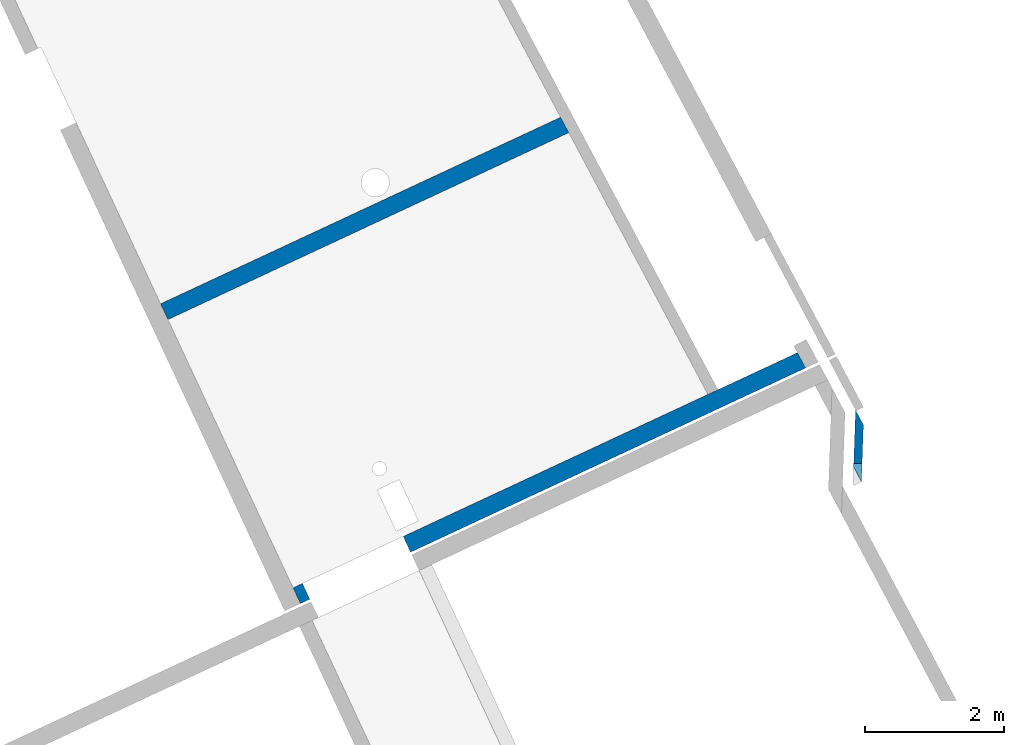
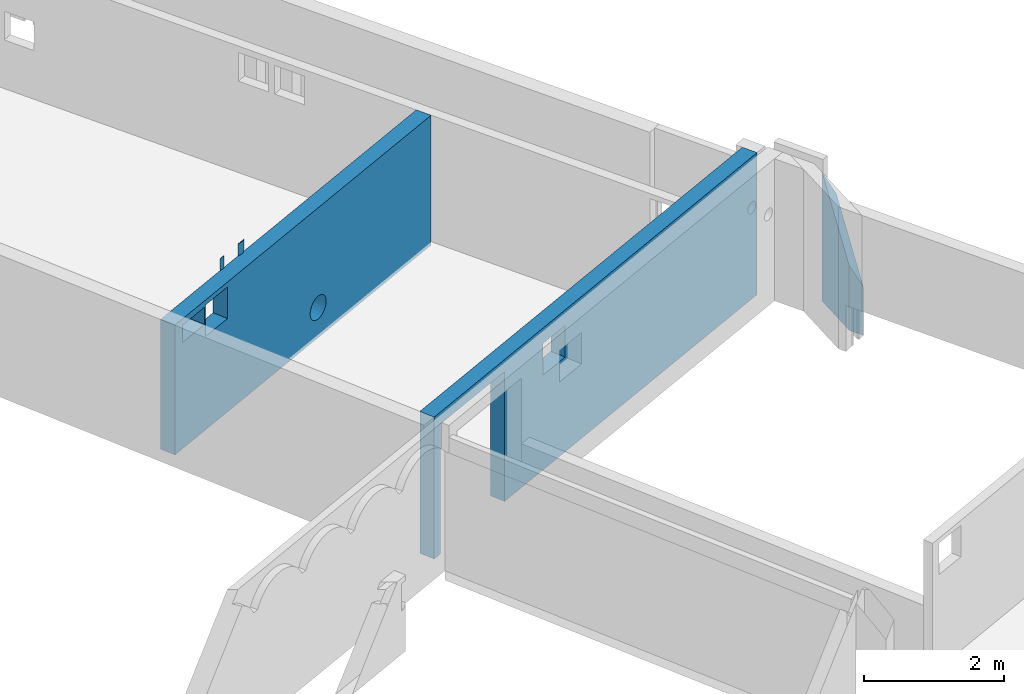
# One storey, part 10 of 13: 3 walls.
"""IFC2X3 building model written with IfcOpenShell, lengths in metres."""

import ifcopenshell
import ifcopenshell.guid

model = None  # the IFC model being written
_history = None  # IfcOwnerHistory: only IFC2X3 demands one
_inside = {}  # id of a spatial element -> (the spatial element, [elements in it])
_under = {}  # id of a project, library or spatial element -> (it, [spatial elements below it])
_declared = {}  # id of a project -> (the project, [libraries it declares])
_typed = {}  # id of a type object -> (the type object, [elements of that type])
_made_of = {}  # id of a material, layer set ... -> (it, [elements and type objects made of it])


def new_model(schema):
    """Start an empty IFC model of exactly this schema.

    Asked for "IFC4X3", IfcOpenShell would pick the latest addendum, in which some entities
    have other attributes; the version numbers below select the first issue.
    IFC2X3 requires an IfcOwnerHistory on every rooted entity: one is made here for all.
    """
    global model, _history
    if schema == "IFC4X3":
        model = ifcopenshell.file(schema_version=(4, 3, 0, 0))
    else:
        model = ifcopenshell.file(schema=schema)
    _inside.clear()
    _under.clear()
    _declared.clear()
    _typed.clear()
    _made_of.clear()
    _history = None
    if model.schema == "IFC2X3":
        org = make("IfcOrganization", Name="unknown")
        user = make(
            "IfcPersonAndOrganization",
            ThePerson=make("IfcPerson", FamilyName="unknown"),
            TheOrganization=org,
        )
        app = make(
            "IfcApplication",
            ApplicationDeveloper=org,
            Version="unknown",
            ApplicationFullName="unknown",
            ApplicationIdentifier="unknown",
        )
        _history = make(
            "IfcOwnerHistory",
            OwningUser=user,
            OwningApplication=app,
            ChangeAction="ADDED",
            CreationDate=0,
        )
    return model


def make(cls, **values):
    """One entity of the class cls with the attributes given. An attribute that is None is left unset."""
    return model.create_entity(
        cls, **{name: value for name, value in values.items() if value is not None}
    )


def entity(cls, *values):
    """Any entity or typed value of the class cls, its attributes in the order of the schema. None: left unset."""
    e = model.create_entity(cls)
    for i, value in enumerate(values):
        if value is not None:
            e[i] = value
    return e


def rooted(cls, **values):
    """An entity with a GlobalId (a new one), such as an element, a storey or a relation."""
    return make(cls, GlobalId=ifcopenshell.guid.new(), OwnerHistory=_history, **values)


def si_unit(unit_type, name, prefix=None):
    """IfcSIUnit, for example si_unit("LENGTHUNIT", "METRE", prefix="MILLI")."""
    return make("IfcSIUnit", UnitType=unit_type, Prefix=prefix, Name=name)


def converted_unit(unit_type, name, factor, base, dimensions=None, offset=None):
    """IfcConversionBasedUnit, such as the inch: factor (a typed value) times the base unit."""
    return make(
        "IfcConversionBasedUnit"
        if offset is None
        else "IfcConversionBasedUnitWithOffset",
        ConversionOffset=offset,
        Dimensions=None
        if dimensions is None
        else entity("IfcDimensionalExponents", *dimensions),
        UnitType=unit_type,
        Name=name,
        ConversionFactor=make(
            "IfcMeasureWithUnit", ValueComponent=factor, UnitComponent=base
        ),
    )


def derived_unit(unit_type, elements):
    """IfcDerivedUnit: a product of units, each with its exponent."""
    return make(
        "IfcDerivedUnit",
        Elements=[
            make("IfcDerivedUnitElement", Unit=unit, Exponent=power)
            for unit, power in elements
        ],
        UnitType=unit_type,
    )


def assignment(units):
    """IfcUnitAssignment: the units of a project."""
    return None if units is None else make("IfcUnitAssignment", Units=units)


def point(xyz):
    """IfcCartesianPoint."""
    return None if xyz is None else make("IfcCartesianPoint", Coordinates=xyz)


def direction(xyz):
    """IfcDirection."""
    return None if xyz is None else make("IfcDirection", DirectionRatios=xyz)


def frame(location, z_axis=None, x_axis=None):
    """IfcAxis2Placement3D, a coordinate frame: its origin and axes. An axis left out is left unset."""
    return make(
        "IfcAxis2Placement3D",
        Location=point(location),
        Axis=direction(z_axis),
        RefDirection=direction(x_axis),
    )


def origin():
    """The frame at (0, 0, 0) with its axes left unset."""
    return frame((0.0, 0.0, 0.0))


def place(relative_to, where):
    """IfcLocalPlacement: puts the frame where relative to a parent placement (None: the world)."""
    return make(
        "IfcLocalPlacement", PlacementRelTo=relative_to, RelativePlacement=where
    )


def context(
    kind, dimensions, precision=None, world=None, true_north=None, identifier=None
):
    """IfcGeometricRepresentationContext, for example the 3D "Model" context."""
    return make(
        "IfcGeometricRepresentationContext",
        ContextIdentifier=identifier,
        ContextType=kind,
        CoordinateSpaceDimension=dimensions,
        Precision=precision,
        WorldCoordinateSystem=world,
        TrueNorth=true_north,
    )


def subcontext(parent, identifier, kind, view, scale=None):
    """IfcGeometricRepresentationSubContext, for example "Body" below "Model"."""
    return make(
        "IfcGeometricRepresentationSubContext",
        ContextIdentifier=identifier,
        ContextType=kind,
        ParentContext=parent,
        TargetScale=scale,
        TargetView=view,
    )


def project(units=None, contexts=None):
    """IfcProject with its units and contexts."""
    return rooted(
        "IfcProject",
        Name="project",
        RepresentationContexts=contexts,
        UnitsInContext=assignment(units),
    )


def spatial(cls, under=None, at=None, **own):
    """A site, building, storey or space (cls), placed at a placement, below another one or the project."""
    s = rooted(cls, ObjectPlacement=at, **own)
    if under is not None:
        _under.setdefault(under.id(), (under, []))[1].append(s)
    return s


def faces_of(points, faces, orient=None, outer=None):
    """IfcFace entities. A face is a list of loops; a loop is a list of indices into points, from 0.

    orient and outer hold one flag for each loop. By default every Orientation is true, the
    first loop of a face is its IfcFaceOuterBound and the others are IfcFaceBound.
    """
    made = []
    for i, loops in enumerate(faces):
        bounds = []
        for j, loop in enumerate(loops):
            is_outer = j == 0 if outer is None else outer[i][j]
            bounds.append(
                make(
                    "IfcFaceOuterBound" if is_outer else "IfcFaceBound",
                    Bound=make("IfcPolyLoop", Polygon=[points[k] for k in loop]),
                    Orientation=True if orient is None else orient[i][j],
                )
            )
        made.append(make("IfcFace", Bounds=bounds))
    return made


def faceted_brep(points, faces, orient=None, outer=None, voids=None):
    """IfcFacetedBrep: a solid bounded by flat faces; with voids (closed shells), ...WithVoids."""
    shared = [point(p) for p in points]
    hull = make("IfcClosedShell", CfsFaces=faces_of(shared, faces, orient, outer))
    if voids is None:
        return make("IfcFacetedBrep", Outer=hull)
    return make(
        "IfcFacetedBrepWithVoids",
        Outer=hull,
        Voids=[
            make(cls, CfsFaces=faces_of(shared, fs, o, b)) for cls, fs, o, b in voids
        ],
    )


def shape(context_of_items, identifier, shape_type, items):
    """IfcShapeRepresentation: the items that make up one representation, for example the "Body"."""
    return make(
        "IfcShapeRepresentation",
        ContextOfItems=context_of_items,
        RepresentationIdentifier=identifier,
        RepresentationType=shape_type,
        Items=items,
    )


def material(Name=None, Category=None):
    """IfcMaterial."""
    return make("IfcMaterial", Name=Name, Category=Category)


def layer(
    of_material, thickness, ventilated=None, Name=None, Category=None, Priority=None
):
    """IfcMaterialLayer: one layer of a wall or slab, of a material (None: an air gap)."""
    return make(
        "IfcMaterialLayer",
        Material=of_material,
        LayerThickness=thickness,
        IsVentilated=ventilated,
        Name=Name,
        Category=Category,
        Priority=Priority,
    )


def layer_set(layers, Name=None):
    """IfcMaterialLayerSet."""
    return make("IfcMaterialLayerSet", MaterialLayers=layers, LayerSetName=Name)


def made_of(thing, what):
    """Note that an element or type object is made of a material, layer set ...; save() writes the relation."""
    if what is not None:
        _made_of.setdefault(what.id(), (what, []))[1].append(thing)
    return thing


def type_object(cls, material=None, **own):
    """A type object (cls), such as IfcWallType, which elements share."""
    return made_of(rooted(cls, **own), material)


def element(
    cls,
    number,
    at=None,
    inside=None,
    cuts=None,
    type_object=None,
    material=None,
    context=None,
    identifier="Body",
    shape_type=None,
    held_by="IfcProductDefinitionShape",
    body=None,
    shapes=None,
    **own,
):
    """One element of the class cls, such as IfcWall. Its Tag is "e" and its number.

    at: its placement. inside: the storey or other place that contains it. cuts: it is an
    opening in that element (IfcRelVoidsElement). A single representation is given by context,
    identifier, shape_type and body (its items); several are given by shapes. held_by: the class
    of the entity that holds the representations. save() writes the other relations.
    """
    e = rooted(cls, Tag="e%d" % number, ObjectPlacement=at, **own)
    if body is not None:
        shapes = [shape(context, identifier, shape_type, body)]
    if shapes is not None:
        e.Representation = make(held_by, Representations=shapes)
    if inside is not None:
        _inside.setdefault(inside.id(), (inside, []))[1].append(e)
    if cuts is not None:
        rooted(
            "IfcRelVoidsElement", RelatingBuildingElement=cuts, RelatedOpeningElement=e
        )
    if type_object is not None:
        _typed.setdefault(type_object.id(), (type_object, []))[1].append(e)
    return made_of(e, material)


def aggregate(whole, parts):
    """IfcRelAggregates: a whole, such as a stair, and the parts it consists of."""
    return rooted("IfcRelAggregates", RelatingObject=whole, RelatedObjects=parts)


def save(model, path):
    """Write the relations noted so far, then the file.

    IfcRelAggregates (storeys below a building ...), IfcRelContainedInSpatialStructure (elements
    in a storey), IfcRelDefinesByType, IfcRelAssociatesMaterial and IfcRelDeclares: one each for
    every whole, place, type object, material and project.
    """
    for whole, parts in _under.values():
        aggregate(whole, parts)
    for where, things in _inside.values():
        rooted(
            "IfcRelContainedInSpatialStructure",
            RelatedElements=things,
            RelatingStructure=where,
        )
    for kind, things in _typed.values():
        rooted("IfcRelDefinesByType", RelatedObjects=things, RelatingType=kind)
    for what, things in _made_of.values():
        rooted("IfcRelAssociatesMaterial", RelatedObjects=things, RelatingMaterial=what)
    for by, libraries in _declared.values():
        rooted("IfcRelDeclares", RelatingContext=by, RelatedDefinitions=libraries)
    model.write(path)


model = new_model("IFC2X3")

# Units and contexts
model_context = context("Model", 3, precision=1e-05, world=origin(), true_north=direction((6.12303176911189e-17, 1.0)))
body_context = subcontext(model_context, "Body", "Model", "MODEL_VIEW")
ifc_project = project(units=[si_unit("LENGTHUNIT", "METRE"), si_unit("AREAUNIT", "SQUARE_METRE"), si_unit("VOLUMEUNIT", "CUBIC_METRE"), converted_unit("PLANEANGLEUNIT", "DEGREE", entity("IfcRatioMeasure", 0.0174532925199433), si_unit("PLANEANGLEUNIT", "RADIAN"), dimensions=[0, 0, 0, 0, 0, 0, 0]), si_unit("MASSUNIT", "GRAM", prefix="KILO"), derived_unit("MASSDENSITYUNIT", [(si_unit("MASSUNIT", "GRAM", prefix="KILO"), 1), (si_unit("LENGTHUNIT", "METRE"), -3)]), si_unit("TIMEUNIT", "SECOND"), si_unit("FREQUENCYUNIT", "HERTZ"), si_unit("THERMODYNAMICTEMPERATUREUNIT", "DEGREE_CELSIUS"), derived_unit("THERMALTRANSMITTANCEUNIT", [(si_unit("MASSUNIT", "GRAM", prefix="KILO"), 1), (si_unit("THERMODYNAMICTEMPERATUREUNIT", "KELVIN"), -1), (si_unit("TIMEUNIT", "SECOND"), -3)]), derived_unit("VOLUMETRICFLOWRATEUNIT", [(si_unit("LENGTHUNIT", "METRE"), 3), (si_unit("TIMEUNIT", "SECOND"), -1)]), si_unit("ELECTRICCURRENTUNIT", "AMPERE"), si_unit("ELECTRICVOLTAGEUNIT", "VOLT"), si_unit("POWERUNIT", "WATT"), si_unit("FORCEUNIT", "NEWTON", prefix="KILO"), si_unit("ILLUMINANCEUNIT", "LUX"), si_unit("LUMINOUSFLUXUNIT", "LUMEN"), si_unit("LUMINOUSINTENSITYUNIT", "CANDELA"), derived_unit("USERDEFINED", [(si_unit("MASSUNIT", "GRAM", prefix="KILO"), -1), (si_unit("LENGTHUNIT", "METRE"), -2), (si_unit("TIMEUNIT", "SECOND"), 3), (si_unit("LUMINOUSFLUXUNIT", "LUMEN"), 1)]), derived_unit("LINEARVELOCITYUNIT", [(si_unit("LENGTHUNIT", "METRE"), 1), (si_unit("TIMEUNIT", "SECOND"), -1)]), si_unit("PRESSUREUNIT", "PASCAL"), derived_unit("USERDEFINED", [(si_unit("LENGTHUNIT", "METRE"), -2), (si_unit("MASSUNIT", "GRAM", prefix="KILO"), 1), (si_unit("TIMEUNIT", "SECOND"), -2)])], contexts=[model_context])

# Site, building, storey
site_placement = place(None, frame((5.36960000000003, 43.3158000000006, 0.0), z_axis=(0.0, 0.0, 1.0), x_axis=(-0.422618261740703, 0.906307787036648, 0.0)))
site = spatial("IfcSite", under=ifc_project, at=site_placement, CompositionType="ELEMENT")
building_placement = place(site_placement, origin())
building = spatial("IfcBuilding", under=site, at=building_placement, CompositionType="ELEMENT")
storey_placement = place(building_placement, frame((0.0, 0.0, 2.56)))
storey = spatial("IfcBuildingStorey", under=building, at=storey_placement, CompositionType="ELEMENT", Elevation=2.56)

# Walls
ifc_material_1 = material(Name="C30/37 XC1")
ifc_layer_1 = layer(ifc_material_1, 0.25)
ifc_layer_set_1 = layer_set([ifc_layer_1])
wall_type_1 = type_object("IfcWallType", PredefinedType="NOTDEFINED", material=ifc_layer_set_1)
wall_1_placement = place(storey_placement, frame((25.000661769643, 9.58252584902448, 0.0), z_axis=(0.0, 0.0, 1.0), x_axis=(0.0, -1.0, 0.0)))
element("IfcWall", 1, at=wall_1_placement, inside=storey, type_object=wall_type_1, Name="XS1", context=body_context, shape_type="Brep", body=[
    faceted_brep([(1.50358237978797, 0.118771363247266, 2.47), (1.53613994546416, 0.117814694640783, 2.47), (1.55817935407453, 0.120195133933422, 2.47), (1.57981994753226, 0.125000000000004, 2.47), (1.47161185614845, 0.124999999999998, 2.47), (1.96175714576713, 0.111808342818854, 2.47), (2.00747128584161, 0.108942082879027, 2.47), (2.04254985835097, 0.113915241549688, 2.47), (2.07620051490559, 0.125000000000003, 2.47), (1.91789396953003, 0.125000000000002, 2.47), (1.30614697775679, -0.124999999999998, 1.62500004725195), (0.0, -0.125, 0.0599999999999999), (0.0, -0.125, 0.0), (3.36393668767899, -0.124999999999999, 0.477136867142488), (3.3581250511642, -0.124999999999999, 0.524999999999999), (3.36393668767899, -0.124999999999999, 0.572863132857511), (3.38103384603356, -0.124999999999999, 0.617944634408753), (3.40842290152998, -0.124999999999999, 0.657624531648158), (0.756146977756795, -0.124999999999998, 1.62500004725195), (3.44451210181797, -0.124999999999998, 0.68959677317873), (1.30614697775679, -0.124999999999998, 2.17500004725195), (0.184060340839717, -0.124999999999998, 1.85), (0.734060340839716, -0.124999999999998, 1.85), (0.756146977756795, -0.124999999999998, 2.17500004725195), (0.734060340839716, -0.124999999999998, 2.15), (0.184060340839717, -0.124999999999998, 2.15), (0.0, -0.125, 2.26), (6.36548056873816, -0.124999999999997, 2.26), (3.38103384603356, -0.124999999999999, 0.432055365591246), (3.40842290152998, -0.124999999999999, 0.39237546835184), (3.44451210181797, -0.124999999999998, 0.360403226821268), (3.48720407375569, -0.124999999999998, 0.337996751462916), (3.53401771511313, -0.124999999999998, 0.326458225180388), (6.36548056873816, -0.124999999999997, 0.0), (3.58223238721526, -0.124999999999997, 0.326458225180387), (3.6290460285727, -0.124999999999997, 0.337996751462916), (3.67173800051043, -0.124999999999997, 0.360403226821267), (3.70782720079842, -0.124999999999996, 0.392375468351839), (3.73521625629484, -0.124999999999996, 0.432055365591244), (3.75231341464941, -0.124999999999996, 0.477136867142486), (6.36548056873816, -0.124999999999997, 0.0599999999999999), (3.7581250511642, -0.124999999999996, 0.524999999999998), (3.75231341464941, -0.124999999999996, 0.57286313285751), (3.73521625629484, -0.124999999999996, 0.617944634408752), (3.70782720079842, -0.124999999999996, 0.657624531648158), (3.48720407375569, -0.124999999999998, 0.712003248537082), (3.53401771511313, -0.124999999999998, 0.723541774819609), (3.58223238721526, -0.124999999999997, 0.723541774819609), (3.62904602857271, -0.124999999999997, 0.712003248537081), (3.67173800051043, -0.124999999999997, 0.68959677317873), (6.35243277988906, 0.125000000000002, 0.0599999999999999), (6.35243277988906, 0.125000000000002, 0.0), (3.75231341464941, 0.125000000000004, 0.477136867142486), (3.7581250511642, 0.125000000000004, 0.524999999999999), (3.75231341464941, 0.125000000000004, 0.57286313285751), (3.73521625629484, 0.125000000000003, 0.617944634408752), (6.35243277988906, 0.125000000000002, 2.26), (3.73521625629484, 0.125000000000003, 0.432055365591244), (3.70782720079842, 0.125000000000003, 0.392375468351839), (3.67173800051043, 0.125000000000003, 0.360403226821267), (3.6290460285727, 0.125000000000003, 0.337996751462916), (3.58223238721526, 0.125000000000002, 0.326458225180387), (3.53401771511313, 0.125000000000002, 0.326458225180388), (0.0, 0.125, 0.0), (3.48720407375569, 0.125000000000001, 0.337996751462916), (3.44451210181797, 0.125000000000001, 0.360403226821268), (3.40842290152998, 0.125000000000001, 0.39237546835184), (3.38103384603356, 0.125000000000001, 0.432055365591246), (3.36393668767899, 0.125, 0.477136867142488), (1.30614697775679, 0.125000000000002, 1.62500004725195), (0.0, 0.125, 0.0599999999999999), (0.756146977756795, 0.125000000000001, 1.62500004725195), (0.184060340839717, 0.125000000000001, 1.85), (0.0, 0.125, 2.26), (0.184060340839717, 0.125000000000001, 2.15), (0.756146977756795, 0.125000000000001, 2.17500004725195), (1.47161185614845, 0.125000000000003, 2.26), (1.30614697775679, 0.125000000000002, 2.17500004725195), (1.57981994753227, 0.125000000000004, 2.26), (1.91789396953003, 0.125000000000002, 2.26), (3.3581250511642, 0.125, 0.524999999999999), (3.36393668767899, 0.125, 0.572863132857511), (3.38103384603356, 0.125000000000001, 0.617944634408753), (2.07620051490558, 0.125000000000003, 2.26), (3.62904602857271, 0.125000000000003, 0.712003248537081), (3.58223238721526, 0.125000000000002, 0.723541774819609), (3.53401771511313, 0.125000000000002, 0.723541774819609), (3.48720407375569, 0.125000000000001, 0.712003248537082), (3.44451210181797, 0.125000000000001, 0.68959677317873), (3.40842290152998, 0.125000000000001, 0.657624531648158), (0.734060340839716, 0.125000000000001, 1.85), (0.734060340839716, 0.125000000000001, 2.15), (3.70782720079842, 0.125000000000003, 0.657624531648158), (3.67173800051043, 0.125000000000003, 0.68959677317873), (1.94682035146414, 0.115079803881545, 2.26), (1.55824777725016, 0.120206401642983, 2.26), (1.53613994546416, 0.117814694640783, 2.26), (1.50353302130633, 0.118776865597135, 2.26), (2.04258286431956, 0.113922956023442, 2.26), (2.00747128584161, 0.108942082879023, 2.26), (1.97685131810173, 0.109692547553949, 2.26)], [[[0, 1, 2, 3, 4]], [[5, 6, 7, 8, 9]], [[10, 11, 12]], [[10, 12, 13]], [[10, 13, 14]], [[15, 10, 14]], [[10, 15, 16]], [[10, 16, 17]], [[10, 18, 11]], [[10, 17, 19]], [[10, 19, 20]], [[21, 11, 18]], [[22, 21, 18]], [[18, 23, 22]], [[22, 23, 24]], [[23, 25, 24]], [[23, 26, 25]], [[23, 20, 26]], [[25, 26, 21]], [[21, 26, 11]], [[26, 20, 27]], [[12, 28, 13]], [[29, 28, 12]], [[30, 29, 12]], [[12, 31, 30]], [[32, 31, 12]], [[32, 12, 33]], [[34, 32, 33]], [[34, 33, 35]], [[36, 35, 33]], [[33, 37, 36]], [[38, 37, 33]], [[39, 38, 33]], [[33, 40, 39]], [[40, 41, 39]], [[41, 40, 42]], [[43, 42, 40]], [[27, 43, 40]], [[44, 43, 27]], [[19, 45, 20]], [[46, 20, 45]], [[47, 20, 46]], [[47, 27, 20]], [[48, 27, 47]], [[48, 49, 27]], [[44, 27, 49]], [[50, 51, 52]], [[50, 52, 53]], [[54, 50, 53]], [[55, 50, 54]], [[55, 56, 50]], [[57, 52, 51]], [[58, 57, 51]], [[58, 51, 59]], [[59, 51, 60]], [[61, 60, 51]], [[62, 61, 51]], [[51, 63, 62]], [[62, 63, 64]], [[65, 64, 63]], [[66, 65, 63]], [[67, 66, 63]], [[68, 67, 63]], [[69, 68, 63]], [[70, 69, 63]], [[69, 70, 71]], [[71, 70, 72]], [[70, 73, 72]], [[74, 72, 73]], [[75, 74, 73]], [[73, 76, 75]], [[76, 77, 75]], [[77, 76, 78]], [[78, 76, 3]], [[76, 4, 3]], [[69, 78, 79]], [[77, 78, 69]], [[80, 68, 69]], [[69, 81, 80]], [[82, 81, 69]], [[83, 82, 69]], [[79, 83, 69]], [[84, 83, 56]], [[84, 85, 83]], [[83, 85, 86]], [[86, 87, 83]], [[83, 87, 88]], [[88, 89, 83]], [[83, 79, 8]], [[83, 89, 82]], [[79, 9, 8]], [[75, 71, 90]], [[91, 75, 90]], [[75, 91, 74]], [[72, 90, 71]], [[92, 56, 55]], [[56, 92, 93]], [[56, 93, 84]], [[70, 63, 12, 11, 26, 73]], [[94, 79, 78, 95, 96, 97, 76, 73, 26, 27, 56, 83, 98, 99, 100]], [[40, 33, 51, 50, 56, 27]], [[23, 18, 71, 75]], [[20, 23, 75, 77]], [[10, 20, 77, 69]], [[18, 10, 69, 71]], [[25, 21, 72, 74]], [[24, 25, 74, 91]], [[22, 24, 91, 90]], [[21, 22, 90, 72]], [[68, 80, 14, 13]], [[68, 13, 28, 67]], [[31, 64, 65, 30]], [[65, 66, 29, 30]], [[66, 67, 28, 29]], [[62, 64, 31, 32]], [[32, 34, 61, 62]], [[60, 61, 34, 35]], [[60, 35, 36, 59]], [[39, 52, 57, 38]], [[57, 58, 37, 38]], [[58, 59, 36, 37]], [[53, 52, 39, 41]], [[54, 53, 41, 42]], [[55, 54, 42, 43]], [[84, 93, 49, 48]], [[93, 92, 44, 49]], [[55, 43, 44, 92]], [[84, 48, 47, 85]], [[47, 46, 86, 85]], [[87, 86, 46, 45]], [[87, 45, 19, 88]], [[15, 81, 82, 16]], [[82, 89, 17, 16]], [[89, 88, 19, 17]], [[80, 81, 15, 14]], [[76, 97, 4]], [[4, 97, 0]], [[0, 96, 1]], [[96, 0, 97]], [[96, 2, 1]], [[2, 96, 95]], [[95, 78, 3]], [[95, 3, 2]], [[79, 94, 9]], [[9, 94, 5]], [[100, 99, 6]], [[6, 5, 100]], [[100, 5, 94]], [[99, 7, 6]], [[7, 99, 98]], [[98, 83, 8]], [[98, 8, 7]], [[63, 51, 33, 12]]]),
])
wall_2_placement = place(storey_placement, frame((20.4906620018759, 9.58252584902452, 0.0), z_axis=(0.0, 0.0, 1.0), x_axis=(0.0, -1.0, 0.0)))
element("IfcWall", 2, at=wall_2_placement, inside=storey, type_object=wall_type_1, Name="XS1", context=body_context, shape_type="Brep", body=[
    faceted_brep([(0.0, 0.125, 0.0), (0.149999999999859, 0.125000000000001, 0.0), (0.149999999999859, -0.124999999999998, 0.0), (0.0, -0.124999999999995, 0.0), (1.74999999999986, 0.125000000000001, 0.0), (8.0098127022329, 0.125000000000002, 0.0), (8.02286049106415, -0.124999999999997, 0.0), (1.74999999999986, -0.124999999999999, 0.0), (0.149999999999859, -0.124999999999998, 2.26), (0.0, -0.125, 2.47), (1.74999999999986, -0.124999999999999, 2.26), (3.25216755771688, -0.124999999999996, 2.20112194109641), (2.70216755771688, -0.124999999999996, 2.20112194109641), (2.70216755771688, -0.124999999999996, 1.65112194109641), (3.25216755771688, -0.124999999999996, 1.65112194109641), (7.80340516427754, -0.124999999999999, 1.53997490455559), (7.81929702653733, -0.124999999999999, 1.51926422643693), (7.84000770465598, -0.124999999999998, 1.50337236417715), (7.86412580014573, -0.124999999999998, 1.49338232192668), (7.89000770465598, -0.124999999999998, 1.48997490455559), (7.91588960916623, -0.124999999999998, 1.49338232192668), (7.94000770465598, -0.124999999999998, 1.50337236417715), (7.96071838277464, -0.124999999999997, 1.51926422643693), (7.97661024503442, -0.124999999999997, 1.53997490455559), (7.98660028728489, -0.124999999999997, 1.56409300004534), (7.99000770465598, -0.124999999999997, 1.58997490455559), (8.02286049106415, -0.124999999999997, 2.47), (7.80340516427754, -0.124999999999999, 1.63997490455559), (7.81929702653733, -0.124999999999999, 1.66068558267424), (7.98660028728489, -0.124999999999997, 1.61585680906584), (7.97661024503442, -0.124999999999997, 1.63997490455559), (7.96071838277464, -0.124999999999997, 1.66068558267424), (7.94000770465598, -0.124999999999998, 1.67657744493403), (7.91588960916623, -0.124999999999998, 1.6865674871845), (7.89000770465598, -0.124999999999998, 1.68997490455559), (7.86412580014573, -0.124999999999998, 1.6865674871845), (7.84000770465598, -0.124999999999998, 1.67657744493403), (7.79341512202707, -0.124999999999999, 1.56409300004534), (7.79000770465598, -0.124999999999999, 1.58997490455559), (7.79341512202707, -0.124999999999999, 1.61585680906584), (7.96071838277464, 0.125000000000002, 1.51926422643693), (7.97661024503443, 0.125000000000002, 1.53997490455559), (7.94000770465598, 0.125000000000002, 1.50337236417715), (7.98660028728489, 0.125000000000002, 1.56409300004534), (7.99000770465598, 0.125000000000002, 1.58997490455559), (7.91588960916623, 0.125000000000002, 1.49338232192668), (7.89000770465598, 0.125000000000002, 1.48997490455559), (7.86412580014573, 0.125000000000001, 1.49338232192668), (7.84000770465598, 0.125000000000001, 1.50337236417715), (7.81929702653733, 0.125000000000001, 1.51926422643693), (8.0098127022329, 0.125000000000002, 2.47), (7.80340516427754, 0.125000000000001, 1.53997490455559), (6.5878148786062, 0.125, 2.47), (3.25216755771688, 0.125000000000004, 1.65112194109641), (2.70216755771688, 0.125000000000004, 1.65112194109641), (1.74999999999986, 0.125000000000001, 2.26), (3.25216755771688, 0.125000000000004, 2.20112194109641), (2.70216755771688, 0.125000000000004, 2.20112194109641), (0.0, 0.125, 2.47), (0.149999999999859, 0.125000000000001, 2.26), (7.79341512202708, 0.125000000000001, 1.56409300004534), (6.74803264374964, 0.125000000000001, 2.47), (7.79000770465598, 0.125000000000001, 1.58997490455559), (7.79341512202708, 0.125000000000001, 1.61585680906584), (7.80340516427754, 0.125000000000001, 1.63997490455559), (7.81929702653733, 0.125000000000001, 1.66068558267424), (7.98660028728489, 0.125000000000002, 1.61585680906584), (7.97661024503443, 0.125000000000002, 1.63997490455559), (7.96071838277464, 0.125000000000002, 1.66068558267424), (7.94000770465598, 0.125000000000002, 1.67657744493403), (7.91588960916623, 0.125000000000002, 1.6865674871845), (7.89000770465598, 0.125000000000002, 1.68997490455559), (7.86412580014573, 0.125000000000001, 1.6865674871845), (7.84000770465598, 0.125000000000001, 1.67657744493403)], [[[0, 1, 2, 3]], [[4, 5, 6, 7]], [[2, 8, 3]], [[8, 9, 3]], [[9, 8, 10]], [[9, 10, 11]], [[10, 12, 11]], [[13, 12, 10]], [[7, 13, 10]], [[14, 13, 7]], [[14, 7, 6]], [[6, 15, 14]], [[15, 6, 16]], [[16, 6, 17]], [[18, 17, 6]], [[19, 18, 6]], [[19, 6, 20]], [[21, 20, 6]], [[6, 22, 21]], [[22, 6, 23]], [[24, 23, 6]], [[25, 24, 6]], [[6, 26, 25]], [[26, 11, 27]], [[26, 27, 28]], [[9, 11, 26]], [[29, 25, 26]], [[30, 29, 26]], [[26, 31, 30]], [[32, 31, 26]], [[32, 26, 33]], [[34, 33, 26]], [[35, 34, 26]], [[36, 35, 26]], [[36, 26, 28]], [[15, 37, 14]], [[14, 37, 38]], [[38, 39, 14]], [[39, 11, 14]], [[39, 27, 11]], [[5, 40, 41]], [[40, 5, 42]], [[41, 43, 5]], [[5, 43, 44]], [[45, 42, 5]], [[46, 45, 5]], [[47, 46, 5]], [[47, 5, 48]], [[5, 49, 48]], [[44, 50, 5]], [[51, 49, 5]], [[51, 5, 52]], [[5, 53, 52]], [[5, 4, 53]], [[53, 4, 54]], [[55, 54, 4]], [[52, 56, 55]], [[57, 54, 55]], [[58, 52, 55]], [[55, 59, 58]], [[55, 56, 57]], [[58, 59, 0]], [[59, 1, 0]], [[52, 53, 56]], [[51, 52, 60]], [[52, 61, 60]], [[62, 60, 61]], [[63, 62, 61]], [[61, 64, 63]], [[64, 61, 65]], [[65, 61, 50]], [[44, 66, 50]], [[67, 50, 66]], [[50, 67, 68]], [[50, 68, 69]], [[69, 70, 50]], [[70, 71, 50]], [[71, 72, 50]], [[73, 50, 72]], [[50, 73, 65]], [[9, 26, 50, 61, 52, 58]], [[10, 55, 4, 7]], [[8, 2, 1, 59]], [[10, 8, 59, 55]], [[6, 5, 50, 26]], [[0, 3, 9, 58]], [[12, 13, 54, 57]], [[11, 12, 57, 56]], [[14, 11, 56, 53]], [[13, 14, 53, 54]], [[60, 62, 38, 37]], [[60, 37, 15, 51]], [[48, 49, 16, 17]], [[16, 49, 51, 15]], [[47, 48, 17, 18]], [[18, 19, 46, 47]], [[42, 45, 20, 21]], [[42, 21, 22, 40]], [[43, 41, 23, 24]], [[23, 41, 40, 22]], [[44, 43, 24, 25]], [[46, 19, 20, 45]], [[29, 30, 67, 66]], [[25, 29, 66, 44]], [[69, 68, 31, 32]], [[67, 30, 31, 68]], [[70, 69, 32, 33]], [[33, 34, 71, 70]], [[73, 72, 35, 36]], [[73, 36, 28, 65]], [[63, 64, 27, 39]], [[27, 64, 65, 28]], [[62, 63, 39, 38]], [[71, 34, 35, 72]]]),
])
ifc_material_2 = material(Name="C30/37 XS1")
ifc_layer_2 = layer(ifc_material_2, 0.12)
ifc_layer_set_2 = layer_set([ifc_layer_2])
wall_type_2 = type_object("IfcWallType", PredefinedType="STANDARD", material=ifc_layer_set_2)
wall_3_placement = place(storey_placement, frame((19.4850527200614, 1.11123291371546, 0.0), z_axis=(0.0, 0.0, 1.0), x_axis=(-0.890908426454519, 0.454182975982515, 0.0)))
element("IfcWall", 3, at=wall_3_placement, inside=storey, type_object=wall_type_2, context=body_context, shape_type="Brep", body=[
    faceted_brep([(0.819686068301262, -0.0599999999999985, 0.800000000000001), (0.819686068301262, -0.0599999999999985, 1.12786235627137), (0.0, -0.0599999999999985, 2.24138565222254), (0.0, -0.0599999999999985, 0.0), (0.819686068301262, -0.0599999999999985, 0.0), (0.207845407441621, 0.0600000000000007, 1.95903279532655), (1.02753216520086, 0.0600000000000012, 0.845508562763734), (1.02753216520086, 0.0600000000000012, 0.0), (0.207845407441618, 0.0600000000000007, 0.0)], [[[0, 1, 2, 3, 4]], [[5, 6, 7, 8]], [[1, 0, 4, 7, 6]], [[2, 5, 8, 3]], [[2, 1, 6, 5]], [[4, 3, 8, 7]]]),
])

save(model, "model.ifc")
